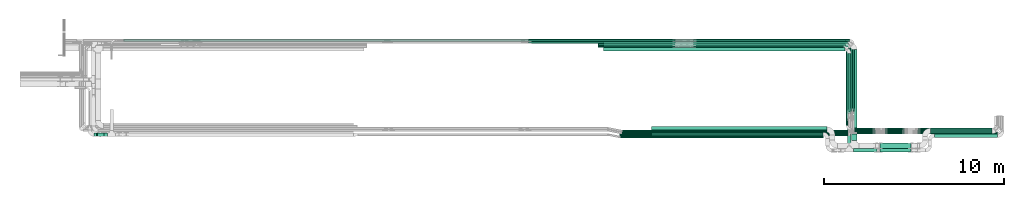
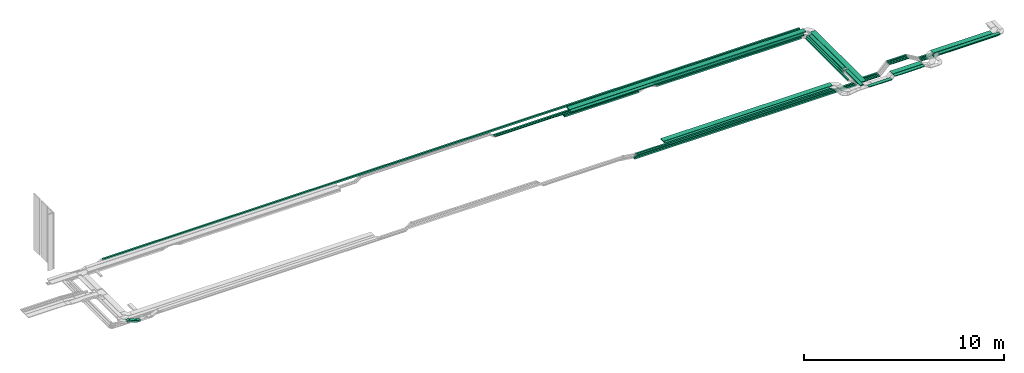
# One storey, part 2 of 19: 41 flow segments.
"""IFC2X3 building model written with IfcOpenShell, lengths in millimetres."""

from ifc_helpers import new_model, entity, si_unit, converted_unit, derived_unit, direction, frame, frame_2d, origin, origin_2d_with_axis, place, context, subcontext, project, spatial, rectangle, extrude, type_object, element, save


model = new_model("IFC2X3")

# Units and contexts
model_context = context("Model", 3, precision=0.01, world=origin(), true_north=direction((6.12303176911189e-17, 1.0)))
body_context = subcontext(model_context, "Body", "Model", "MODEL_VIEW")
ifc_project = project(units=[si_unit("LENGTHUNIT", "METRE", prefix="MILLI"), si_unit("AREAUNIT", "SQUARE_METRE"), si_unit("VOLUMEUNIT", "CUBIC_METRE"), converted_unit("PLANEANGLEUNIT", "DEGREE", entity("IfcRatioMeasure", 0.0174532925199433), si_unit("PLANEANGLEUNIT", "RADIAN"), dimensions=[0, 0, 0, 0, 0, 0, 0]), si_unit("MASSUNIT", "GRAM", prefix="KILO"), derived_unit("MASSDENSITYUNIT", [(si_unit("MASSUNIT", "GRAM", prefix="KILO"), 1), (si_unit("LENGTHUNIT", "METRE"), -3)]), derived_unit("MOMENTOFINERTIAUNIT", [(si_unit("LENGTHUNIT", "METRE"), 4)]), si_unit("TIMEUNIT", "SECOND"), si_unit("FREQUENCYUNIT", "HERTZ"), si_unit("THERMODYNAMICTEMPERATUREUNIT", "DEGREE_CELSIUS"), derived_unit("THERMALTRANSMITTANCEUNIT", [(si_unit("MASSUNIT", "GRAM", prefix="KILO"), 1), (si_unit("THERMODYNAMICTEMPERATUREUNIT", "KELVIN"), -1), (si_unit("TIMEUNIT", "SECOND"), -3)]), derived_unit("VOLUMETRICFLOWRATEUNIT", [(si_unit("LENGTHUNIT", "METRE"), 3), (si_unit("TIMEUNIT", "SECOND"), -1)]), derived_unit("MASSFLOWRATEUNIT", [(si_unit("MASSUNIT", "GRAM", prefix="KILO"), 1), (si_unit("TIMEUNIT", "SECOND"), -1)]), derived_unit("ROTATIONALFREQUENCYUNIT", [(si_unit("TIMEUNIT", "SECOND"), -1)]), si_unit("ELECTRICCURRENTUNIT", "AMPERE"), si_unit("ELECTRICVOLTAGEUNIT", "VOLT"), si_unit("POWERUNIT", "WATT"), si_unit("FORCEUNIT", "NEWTON", prefix="KILO"), si_unit("ILLUMINANCEUNIT", "LUX"), si_unit("LUMINOUSFLUXUNIT", "LUMEN"), si_unit("LUMINOUSINTENSITYUNIT", "CANDELA"), derived_unit("USERDEFINED", [(si_unit("MASSUNIT", "GRAM", prefix="KILO"), -1), (si_unit("LENGTHUNIT", "METRE"), -2), (si_unit("TIMEUNIT", "SECOND"), 3), (si_unit("LUMINOUSFLUXUNIT", "LUMEN"), 1)]), derived_unit("LINEARVELOCITYUNIT", [(si_unit("LENGTHUNIT", "METRE"), 1), (si_unit("TIMEUNIT", "SECOND"), -1)]), si_unit("PRESSUREUNIT", "PASCAL"), derived_unit("USERDEFINED", [(si_unit("LENGTHUNIT", "METRE"), -2), (si_unit("MASSUNIT", "GRAM", prefix="KILO"), 1), (si_unit("TIMEUNIT", "SECOND"), -2)]), derived_unit("LINEARFORCEUNIT", [(si_unit("MASSUNIT", "GRAM", prefix="KILO"), 1), (si_unit("LENGTHUNIT", "METRE"), 1), (si_unit("TIMEUNIT", "SECOND"), -2), (si_unit("LENGTHUNIT", "METRE"), -1)]), derived_unit("PLANARFORCEUNIT", [(si_unit("MASSUNIT", "GRAM", prefix="KILO"), 1), (si_unit("LENGTHUNIT", "METRE"), 1), (si_unit("TIMEUNIT", "SECOND"), -2), (si_unit("LENGTHUNIT", "METRE"), -2)])], contexts=[model_context])

# Site, building, storey
site_placement = place(None, origin())
site = spatial("IfcSite", under=ifc_project, at=site_placement, CompositionType="ELEMENT")
building_placement = place(site_placement, origin())
building = spatial("IfcBuilding", under=site, at=building_placement, CompositionType="ELEMENT")
storey_placement = place(building_placement, frame((0.0, 0.0, 12000.0)))
storey = spatial("IfcBuildingStorey", under=building, at=storey_placement, CompositionType="ELEMENT", Elevation=12000.0)

# Flow segments
cable_carrier_segment_type = type_object("IfcCableCarrierSegmentType", PredefinedType="CABLETRAYSEGMENT")
flow_segment_1_placement = place(storey_placement, frame((60092.55, 10765.81, 2800.0)))
element("IfcFlowSegment", 1, at=flow_segment_1_placement, inside=storey, type_object=cable_carrier_segment_type, context=body_context, shape_type="SweptSolid", body=[
    extrude(rectangle(XDim=3330.54307637442, YDim=200.000000000007, at=origin_2d_with_axis()), frame((100.0, 1665.27, 0.0), z_axis=(0.0, 0.0, 1.0), x_axis=(0.0, 1.0, 0.0)), (0.0, 0.0, 1.0), 50.0000000000016),
])
flow_segment_2_placement = place(storey_placement, frame((60312.55, 9254.99, 2800.0)))
element("IfcFlowSegment", 2, at=flow_segment_2_placement, inside=storey, type_object=cable_carrier_segment_type, context=body_context, shape_type="SweptSolid", body=[
    extrude(rectangle(XDim=5059.2335274679, YDim=300.000000000001, at=origin_2d_with_axis()), frame((150.0, 2529.62, 0.0), z_axis=(0.0, 0.0, 1.0), x_axis=(0.0, 1.0, 0.0)), (0.0, 0.0, 1.0), 49.9999999999995),
])
flow_segment_3_placement = place(storey_placement, frame((46508.53, 14247.35, 2800.0)))
element("IfcFlowSegment", 3, at=flow_segment_3_placement, inside=storey, type_object=cable_carrier_segment_type, context=body_context, shape_type="SweptSolid", body=[
    extrude(rectangle(XDim=13433.0240063567, YDim=200.000000000002, at=origin_2d_with_axis()), frame((6716.51, 100.0, 0.0), z_axis=(0.0, 0.0, 1.0), x_axis=(-1.0, 0.0, 0.0)), (0.0, 0.0, 1.0), 50.0000000000016),
])
flow_segment_4_placement = place(storey_placement, frame((60368.35, 10890.35, 2500.0)))
element("IfcFlowSegment", 4, at=flow_segment_4_placement, inside=storey, type_object=cable_carrier_segment_type, context=body_context, shape_type="SweptSolid", body=[
    extrude(rectangle(XDim=3751.14255376512, YDim=99.9999999999946, at=origin_2d_with_axis()), frame((50.0, 1875.57, 0.0), z_axis=(0.0, 0.0, 1.0), x_axis=(0.0, -1.0, 0.0)), (0.0, 0.0, 1.0), 49.9999999999995),
])
flow_segment_5_placement = place(storey_placement, frame((60250.78, 10890.35, 2500.0)))
element("IfcFlowSegment", 5, at=flow_segment_5_placement, inside=storey, type_object=cable_carrier_segment_type, context=body_context, shape_type="SweptSolid", body=[
    extrude(rectangle(XDim=3632.27563899094, YDim=99.9999999999946, at=origin_2d_with_axis()), frame((50.0, 1816.14, 0.0), z_axis=(0.0, 0.0, 1.0), x_axis=(0.0, 1.0, 0.0)), (0.0, 0.0, 1.0), 50.0000000000038),
])
flow_segment_6_placement = place(storey_placement, frame((60138.97, 10847.29, 2500.0)))
element("IfcFlowSegment", 6, at=flow_segment_6_placement, inside=storey, type_object=cable_carrier_segment_type, context=body_context, shape_type="SweptSolid", body=[
    extrude(rectangle(XDim=3567.9496186023, YDim=99.9999999999946, at=origin_2d_with_axis()), frame((50.0, 1783.97, 0.0), z_axis=(0.0, 0.0, 1.0), x_axis=(0.0, 1.0, 0.0)), (0.0, 0.0, 1.0), 99.9999999999989),
])
flow_segment_7_placement = place(storey_placement, frame((46208.53, 14442.5, 2500.0)))
element("IfcFlowSegment", 7, at=flow_segment_7_placement, inside=storey, type_object=cable_carrier_segment_type, context=body_context, shape_type="SweptSolid", body=[
    extrude(rectangle(XDim=4287.07760645673, YDim=99.9999999999989, at=origin_2d_with_axis()), frame((2143.54, 50.0, 0.0), z_axis=(0.0, 0.0, 1.0), x_axis=(-1.0, 0.0, 0.0)), (0.0, 0.0, 1.0), 99.9999999999989),
])
flow_segment_8_placement = place(storey_placement, frame((19798.06, 14792.5, 2800.0)))
element("IfcFlowSegment", 8, at=flow_segment_8_placement, inside=storey, type_object=cable_carrier_segment_type, context=body_context, shape_type="SweptSolid", body=[
    extrude(rectangle(XDim=40187.0284882172, YDim=99.9999999999989, at=origin_2d_with_axis()), frame((20093.51, 50.0, 0.0)), (0.0, 0.0, 1.0), 99.9999999999989),
])
flow_segment_9_placement = place(storey_placement, frame((47415.32, 9517.13, 2500.0)))
element("IfcFlowSegment", 9, at=flow_segment_9_placement, inside=storey, type_object=cable_carrier_segment_type, context=body_context, shape_type="SweptSolid", body=[
    extrude(rectangle(XDim=12780.0, YDim=100.000000000001, at=origin_2d_with_axis()), frame((6390.0, 50.0, 0.0), z_axis=(0.0, 0.0, 1.0), x_axis=(-1.0, 0.0, 0.0)), (0.0, 0.0, 1.0), 99.9999999999989),
])
flow_segment_10_placement = place(storey_placement, frame((47436.29, 9407.45, 2800.0)))
element("IfcFlowSegment", 10, at=flow_segment_10_placement, inside=storey, type_object=cable_carrier_segment_type, context=body_context, shape_type="SweptSolid", body=[
    extrude(rectangle(XDim=11318.649842592, YDim=100.000000000001, at=origin_2d_with_axis()), frame((5659.32, 50.0, 0.0)), (0.0, 0.0, 1.0), 99.9999999999989),
])
flow_segment_11_placement = place(storey_placement, frame((49194.94, 9517.13, 2800.0)))
element("IfcFlowSegment", 11, at=flow_segment_11_placement, inside=storey, type_object=cable_carrier_segment_type, context=body_context, shape_type="SweptSolid", body=[
    extrude(rectangle(XDim=9534.94822520535, YDim=200.0, at=origin_2d_with_axis()), frame((4767.47, 100.0, 0.0), z_axis=(0.0, 0.0, 1.0), x_axis=(-1.0, 0.0, 0.0)), (0.0, 0.0, 1.0), 50.0000000000038),
])
flow_segment_12_placement = place(storey_placement, frame((49194.94, 9727.13, 2800.0)))
element("IfcFlowSegment", 12, at=flow_segment_12_placement, inside=storey, type_object=cable_carrier_segment_type, context=body_context, shape_type="SweptSolid", body=[
    extrude(rectangle(XDim=9744.94822520536, YDim=300.000000000001, at=origin_2d_with_axis()), frame((4872.47, 150.0, 0.0), z_axis=(0.0, 0.0, 1.0), x_axis=(-1.0, 0.0, 0.0)), (0.0, 0.0, 1.0), 50.0000000000016),
])
flow_segment_13_placement = place(storey_placement, frame((18293.17, 9487.45, 2637.31)))
element("IfcFlowSegment", 13, at=flow_segment_13_placement, inside=storey, type_object=cable_carrier_segment_type, context=body_context, shape_type="SweptSolid", body=[
    extrude(rectangle(XDim=100.000000000001, YDim=200.0, at=frame_2d((0.0, 0.0), x_axis=(0.0, 1.0))), frame((19.54, 100.0, 208.01), z_axis=(0.920504853454354, 0.0, -0.390731128484766), x_axis=(0.0, 1.0, 0.0)), (0.0, 0.0, 1.0), 414.56320839292),
])
flow_segment_14_placement = place(storey_placement, frame((18717.33, 9487.45, 2628.65)))
element("IfcFlowSegment", 14, at=flow_segment_14_placement, inside=storey, type_object=cable_carrier_segment_type, context=body_context, shape_type="SweptSolid", body=[
    extrude(rectangle(XDim=179.180863905857, YDim=200.0, at=origin_2d_with_axis()), frame((89.59, 100.0, 0.0)), (0.0, 0.0, 1.0), 99.9999999999989),
])
flow_segment_15_placement = place(storey_placement, frame((18152.67, 9487.45, 2800.0)))
element("IfcFlowSegment", 15, at=flow_segment_15_placement, inside=storey, type_object=cable_carrier_segment_type, context=body_context, shape_type="SweptSolid", body=[
    extrude(rectangle(XDim=137.013575831118, YDim=200.0, at=origin_2d_with_axis()), frame((68.51, 100.0, 0.0), z_axis=(0.0, 0.0, 1.0), x_axis=(-1.0, 0.0, 0.0)), (0.0, 0.0, 1.0), 99.9999999999989),
])
flow_segment_16_placement = place(storey_placement, frame((42324.0, 14792.5, 2500.0)))
element("IfcFlowSegment", 16, at=flow_segment_16_placement, inside=storey, type_object=cable_carrier_segment_type, context=body_context, shape_type="SweptSolid", body=[
    extrude(rectangle(XDim=8178.82950919114, YDim=99.9999999999989, at=origin_2d_with_axis()), frame((4089.41, 50.0, 0.0), z_axis=(0.0, 0.0, 1.0), x_axis=(-1.0, 0.0, 0.0)), (0.0, 0.0, 1.0), 50.0000000000016),
])
flow_segment_17_placement = place(storey_placement, frame((42335.11, 14673.63, 2500.0)))
element("IfcFlowSegment", 17, at=flow_segment_17_placement, inside=storey, type_object=cable_carrier_segment_type, context=body_context, shape_type="SweptSolid", body=[
    extrude(rectangle(XDim=8167.71993590031, YDim=99.9999999999989, at=origin_2d_with_axis()), frame((4083.86, 50.0, 0.0)), (0.0, 0.0, 1.0), 50.0000000000016),
])
flow_segment_18_placement = place(storey_placement, frame((51517.42, 14566.24, 2500.0)))
element("IfcFlowSegment", 18, at=flow_segment_18_placement, inside=storey, type_object=cable_carrier_segment_type, context=body_context, shape_type="SweptSolid", body=[
    extrude(rectangle(XDim=8470.54282281095, YDim=99.9999999999989, at=origin_2d_with_axis()), frame((4235.27, 50.0, 0.0), z_axis=(0.0, 0.0, 1.0), x_axis=(-1.0, 0.0, 0.0)), (0.0, 0.0, 1.0), 99.9999999999989),
])
flow_segment_19_placement = place(storey_placement, frame((51517.42, 14442.5, 2500.0)))
element("IfcFlowSegment", 19, at=flow_segment_19_placement, inside=storey, type_object=cable_carrier_segment_type, context=body_context, shape_type="SweptSolid", body=[
    extrude(rectangle(XDim=8361.57508724892, YDim=99.9999999999989, at=origin_2d_with_axis()), frame((4180.79, 50.0, 0.0), z_axis=(0.0, 0.0, 1.0), x_axis=(-1.0, 0.0, 0.0)), (0.0, 0.0, 1.0), 99.9999999999989),
])
flow_segment_20_placement = place(storey_placement, frame((51516.73, 14792.5, 2500.0)))
element("IfcFlowSegment", 20, at=flow_segment_20_placement, inside=storey, type_object=cable_carrier_segment_type, context=body_context, shape_type="SweptSolid", body=[
    extrude(rectangle(XDim=8700.62123170197, YDim=99.9999999999989, at=origin_2d_with_axis()), frame((4350.31, 50.0, 0.0), z_axis=(0.0, 0.0, 1.0), x_axis=(-1.0, 0.0, 0.0)), (0.0, 0.0, 1.0), 50.0000000000016),
])
flow_segment_21_placement = place(storey_placement, frame((51516.73, 14673.63, 2500.0)))
element("IfcFlowSegment", 21, at=flow_segment_21_placement, inside=storey, type_object=cable_carrier_segment_type, context=body_context, shape_type="SweptSolid", body=[
    extrude(rectangle(XDim=8583.05098846206, YDim=99.9999999999989, at=origin_2d_with_axis()), frame((4291.53, 50.0, 0.0), z_axis=(0.0, 0.0, 1.0), x_axis=(-1.0, 0.0, 0.0)), (0.0, 0.0, 1.0), 50.0000000000016),
])
flow_segment_22_placement = place(storey_placement, frame((46208.53, 14566.24, 2500.0)))
element("IfcFlowSegment", 22, at=flow_segment_22_placement, inside=storey, type_object=cable_carrier_segment_type, context=body_context, shape_type="SweptSolid", body=[
    extrude(rectangle(XDim=4287.07760645671, YDim=99.9999999999989, at=origin_2d_with_axis()), frame((2143.54, 50.0, 0.0), z_axis=(0.0, 0.0, 1.0), x_axis=(-1.0, 0.0, 0.0)), (0.0, 0.0, 1.0), 99.9999999999989),
])
flow_segment_23_placement = place(storey_placement, frame((46508.53, 14465.22, 2800.0)))
element("IfcFlowSegment", 23, at=flow_segment_23_placement, inside=storey, type_object=cable_carrier_segment_type, context=body_context, shape_type="SweptSolid", body=[
    extrude(rectangle(XDim=13653.0240063567, YDim=300.000000000001, at=origin_2d_with_axis()), frame((6826.51, 150.0, 0.0), z_axis=(0.0, 0.0, 1.0), x_axis=(-1.0, 0.0, 0.0)), (0.0, 0.0, 1.0), 50.0000000000016),
])
flow_segment_24_placement = place(storey_placement, frame((60030.0, 10095.99, 2500.0)))
element("IfcFlowSegment", 24, at=flow_segment_24_placement, inside=storey, type_object=cable_carrier_segment_type, context=body_context, shape_type="SweptSolid", body=[
    extrude(rectangle(XDim=4195.50902138004, YDim=99.9999999999946, at=origin_2d_with_axis()), frame((50.0, 2097.75, 0.0), z_axis=(0.0, 0.0, 1.0), x_axis=(0.0, -1.0, 0.0)), (0.0, 0.0, 1.0), 99.9999999999989),
])
flow_segment_25_placement = place(storey_placement, frame((60281.0, 9844.99, 2500.0)))
element("IfcFlowSegment", 25, at=flow_segment_25_placement, inside=storey, type_object=cable_carrier_segment_type, context=body_context, shape_type="SweptSolid", body=[
    extrude(rectangle(XDim=1335.63246763187, YDim=99.9999999999989, at=origin_2d_with_axis()), frame((667.82, 50.0, 0.0)), (0.0, 0.0, 1.0), 99.9999999999989),
])
flow_segment_26_placement = place(storey_placement, frame((60301.78, 9734.99, 2500.0)))
element("IfcFlowSegment", 26, at=flow_segment_26_placement, inside=storey, type_object=cable_carrier_segment_type, context=body_context, shape_type="SweptSolid", body=[
    extrude(rectangle(XDim=1335.56305869098, YDim=99.9999999999989, at=origin_2d_with_axis()), frame((667.78, 50.0, 0.0)), (0.0, 0.0, 1.0), 49.9999999999995),
])
flow_segment_27_placement = place(storey_placement, frame((60419.35, 9624.99, 2500.0)))
element("IfcFlowSegment", 27, at=flow_segment_27_placement, inside=storey, type_object=cable_carrier_segment_type, context=body_context, shape_type="SweptSolid", body=[
    extrude(rectangle(XDim=1217.99281545122, YDim=99.9999999999989, at=origin_2d_with_axis()), frame((609.0, 50.0, 0.0)), (0.0, 0.0, 1.0), 50.0000000000038),
])
flow_segment_28_placement = place(storey_placement, frame((60092.55, 8943.82, 2870.0)))
element("IfcFlowSegment", 28, at=flow_segment_28_placement, inside=storey, type_object=cable_carrier_segment_type, context=body_context, shape_type="SweptSolid", body=[
    extrude(rectangle(XDim=1551.11311760389, YDim=200.000000000007, at=origin_2d_with_axis()), frame((100.0, 775.56, 0.0), z_axis=(0.0, 0.0, 1.0), x_axis=(0.0, 1.0, 0.0)), (0.0, 0.0, 1.0), 50.0000000000016),
])
flow_segment_29_placement = place(storey_placement, frame((60422.55, 8613.82, 2870.0)))
element("IfcFlowSegment", 29, at=flow_segment_29_placement, inside=storey, type_object=cable_carrier_segment_type, context=body_context, shape_type="SweptSolid", body=[
    extrude(rectangle(XDim=1304.54319905022, YDim=200.0, at=origin_2d_with_axis()), frame((652.27, 100.0, 0.0)), (0.0, 0.0, 1.0), 50.0000000000016),
])
flow_segment_30_placement = place(storey_placement, frame((62178.37, 9844.99, 3015.0)))
element("IfcFlowSegment", 30, at=flow_segment_30_placement, inside=storey, type_object=cable_carrier_segment_type, context=body_context, shape_type="SweptSolid", body=[
    extrude(rectangle(XDim=1109.47153976734, YDim=99.9999999999989, at=origin_2d_with_axis()), frame((554.74, 50.0, 0.0)), (0.0, 0.0, 1.0), 99.9999999999989),
])
flow_segment_31_placement = place(storey_placement, frame((62178.37, 9734.99, 3015.0)))
element("IfcFlowSegment", 31, at=flow_segment_31_placement, inside=storey, type_object=cable_carrier_segment_type, context=body_context, shape_type="SweptSolid", body=[
    extrude(rectangle(XDim=1109.47153976733, YDim=99.9999999999989, at=origin_2d_with_axis()), frame((554.74, 50.0, 0.0)), (0.0, 0.0, 1.0), 50.0000000000038),
])
flow_segment_32_placement = place(storey_placement, frame((62178.37, 9624.99, 3015.0)))
element("IfcFlowSegment", 32, at=flow_segment_32_placement, inside=storey, type_object=cable_carrier_segment_type, context=body_context, shape_type="SweptSolid", body=[
    extrude(rectangle(XDim=1109.47153976728, YDim=99.9999999999989, at=origin_2d_with_axis()), frame((554.74, 50.0, 0.0), z_axis=(0.0, 0.0, 1.0), x_axis=(-1.0, 0.0, 0.0)), (0.0, 0.0, 1.0), 49.9999999999995),
])
flow_segment_33_placement = place(storey_placement, frame((61898.12, 8824.99, 3015.0)))
element("IfcFlowSegment", 33, at=flow_segment_33_placement, inside=storey, type_object=cable_carrier_segment_type, context=body_context, shape_type="SweptSolid", body=[
    extrude(rectangle(XDim=1716.47133961725, YDim=299.999999999999, at=origin_2d_with_axis()), frame((858.24, 150.0, 0.0)), (0.0, 0.0, 1.0), 50.0000000000016),
])
flow_segment_34_placement = place(storey_placement, frame((61898.12, 8613.82, 3015.0)))
element("IfcFlowSegment", 34, at=flow_segment_34_placement, inside=storey, type_object=cable_carrier_segment_type, context=body_context, shape_type="SweptSolid", body=[
    extrude(rectangle(XDim=1716.48336829874, YDim=200.0, at=origin_2d_with_axis()), frame((858.24, 100.0, 0.0)), (0.0, 0.0, 1.0), 50.0000000000016),
])
flow_segment_35_placement = place(storey_placement, frame((64013.41, 9844.99, 2600.0)))
element("IfcFlowSegment", 35, at=flow_segment_35_placement, inside=storey, type_object=cable_carrier_segment_type, context=body_context, shape_type="SweptSolid", body=[
    extrude(rectangle(XDim=4223.08121112039, YDim=99.9999999999989, at=origin_2d_with_axis()), frame((2111.54, 50.0, 0.0), z_axis=(0.0, 0.0, 1.0), x_axis=(-1.0, 0.0, 0.0)), (0.0, 0.0, 1.0), 99.9999999999989),
])
flow_segment_36_placement = place(storey_placement, frame((63999.6, 9734.99, 2600.0)))
element("IfcFlowSegment", 36, at=flow_segment_36_placement, inside=storey, type_object=cable_carrier_segment_type, context=body_context, shape_type="SweptSolid", body=[
    extrude(rectangle(XDim=4339.65085120224, YDim=99.9999999999989, at=origin_2d_with_axis()), frame((2169.83, 50.0, 0.0)), (0.0, 0.0, 1.0), 50.0000000000016),
])
flow_segment_37_placement = place(storey_placement, frame((63999.6, 9624.99, 2600.0)))
element("IfcFlowSegment", 37, at=flow_segment_37_placement, inside=storey, type_object=cable_carrier_segment_type, context=body_context, shape_type="SweptSolid", body=[
    extrude(rectangle(XDim=4444.60515848698, YDim=99.9999999999989, at=origin_2d_with_axis()), frame((2222.3, 50.0, 0.0)), (0.0, 0.0, 1.0), 50.0000000000016),
])
flow_segment_38_placement = place(storey_placement, frame((64707.44, 9644.99, 2800.0)))
element("IfcFlowSegment", 38, at=flow_segment_38_placement, inside=storey, type_object=cable_carrier_segment_type, context=body_context, shape_type="SweptSolid", body=[
    extrude(rectangle(XDim=3429.05942634583, YDim=300.000000000001, at=origin_2d_with_axis()), frame((1714.53, 150.0, 0.0), z_axis=(0.0, 0.0, 1.0), x_axis=(-1.0, 0.0, 0.0)), (0.0, 0.0, 1.0), 50.0000000000016),
])
flow_segment_39_placement = place(storey_placement, frame((64926.23, 9424.99, 2800.0)))
element("IfcFlowSegment", 39, at=flow_segment_39_placement, inside=storey, type_object=cable_carrier_segment_type, context=body_context, shape_type="SweptSolid", body=[
    extrude(rectangle(XDim=3526.7213158754, YDim=200.0, at=origin_2d_with_axis()), frame((1763.36, 100.0, 0.0), z_axis=(0.0, 0.0, 1.0), x_axis=(-1.0, 0.0, 0.0)), (0.0, 0.0, 1.0), 50.0000000000016),
])
flow_segment_40_placement = place(storey_placement, frame((47530.97, 9624.99, 2500.0)))
element("IfcFlowSegment", 40, at=flow_segment_40_placement, inside=storey, type_object=cable_carrier_segment_type, context=body_context, shape_type="SweptSolid", body=[
    extrude(rectangle(XDim=12887.3753101715, YDim=99.9999999999989, at=origin_2d_with_axis()), frame((6443.69, 50.0, 0.0), z_axis=(0.0, 0.0, 1.0), x_axis=(-1.0, 0.0, 0.0)), (0.0, 0.0, 1.0), 50.0000000000016),
])
flow_segment_41_placement = place(storey_placement, frame((47545.15, 9734.99, 2500.0)))
element("IfcFlowSegment", 41, at=flow_segment_41_placement, inside=storey, type_object=cable_carrier_segment_type, context=body_context, shape_type="SweptSolid", body=[
    extrude(rectangle(XDim=12755.6313526395, YDim=99.9999999999989, at=origin_2d_with_axis()), frame((6377.82, 50.0, 0.0), z_axis=(0.0, 0.0, 1.0), x_axis=(-1.0, 0.0, 0.0)), (0.0, 0.0, 1.0), 50.0000000000016),
])

save(model, "model.ifc")
